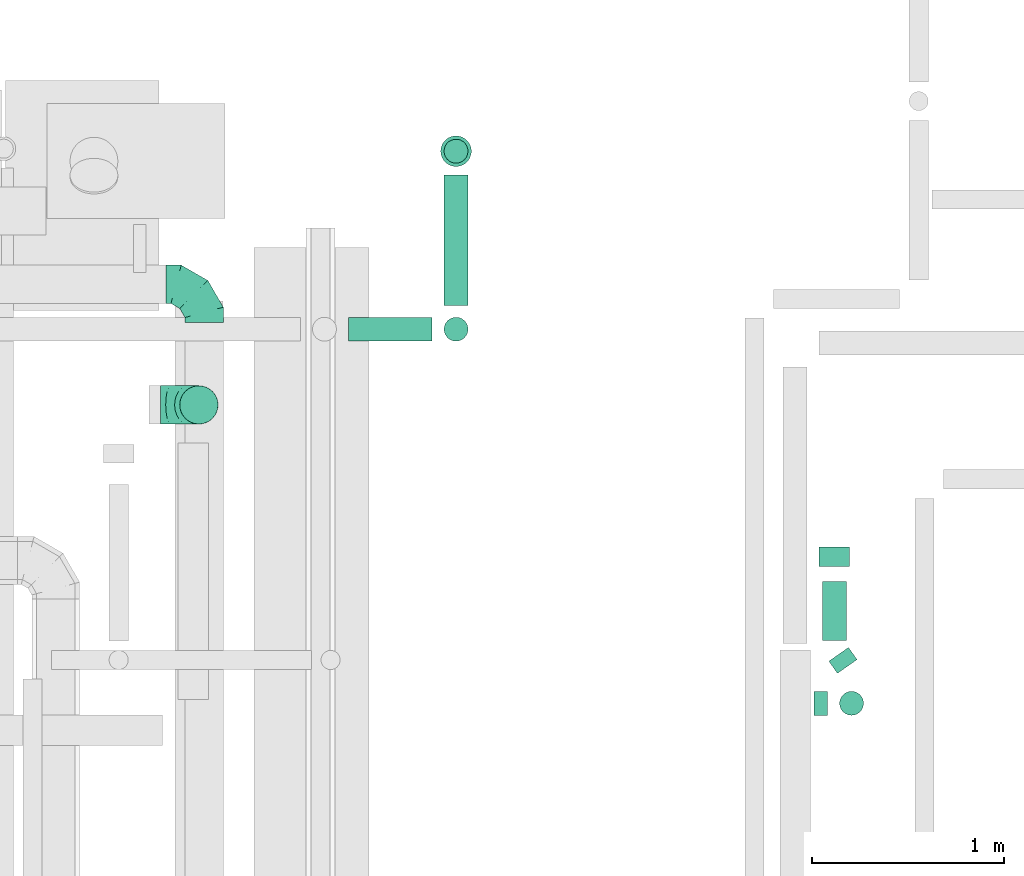
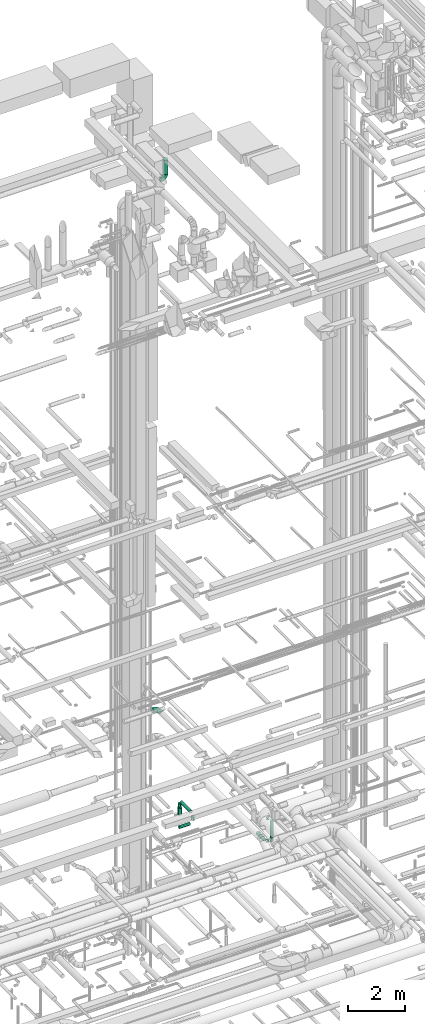
# One storey, part 294 of 337: 11 flow segments, 3 flow fittings.
"""IFC2X3 building model written with IfcOpenShell, lengths in millimetres."""

import ifcopenshell
import ifcopenshell.guid

model = None  # the IFC model being written
_history = None  # IfcOwnerHistory: only IFC2X3 demands one
_inside = {}  # id of a spatial element -> (the spatial element, [elements in it])
_under = {}  # id of a project, library or spatial element -> (it, [spatial elements below it])
_declared = {}  # id of a project -> (the project, [libraries it declares])
_typed = {}  # id of a type object -> (the type object, [elements of that type])
_made_of = {}  # id of a material, layer set ... -> (it, [elements and type objects made of it])


def new_model(schema):
    """Start an empty IFC model of exactly this schema.

    Asked for "IFC4X3", IfcOpenShell would pick the latest addendum, in which some entities
    have other attributes; the version numbers below select the first issue.
    IFC2X3 requires an IfcOwnerHistory on every rooted entity: one is made here for all.
    """
    global model, _history
    if schema == "IFC4X3":
        model = ifcopenshell.file(schema_version=(4, 3, 0, 0))
    else:
        model = ifcopenshell.file(schema=schema)
    _inside.clear()
    _under.clear()
    _declared.clear()
    _typed.clear()
    _made_of.clear()
    _history = None
    if model.schema == "IFC2X3":
        org = make("IfcOrganization", Name="unknown")
        user = make(
            "IfcPersonAndOrganization",
            ThePerson=make("IfcPerson", FamilyName="unknown"),
            TheOrganization=org,
        )
        app = make(
            "IfcApplication",
            ApplicationDeveloper=org,
            Version="unknown",
            ApplicationFullName="unknown",
            ApplicationIdentifier="unknown",
        )
        _history = make(
            "IfcOwnerHistory",
            OwningUser=user,
            OwningApplication=app,
            ChangeAction="ADDED",
            CreationDate=0,
        )
    return model


def make(cls, **values):
    """One entity of the class cls with the attributes given. An attribute that is None is left unset."""
    return model.create_entity(
        cls, **{name: value for name, value in values.items() if value is not None}
    )


def entity(cls, *values):
    """Any entity or typed value of the class cls, its attributes in the order of the schema. None: left unset."""
    e = model.create_entity(cls)
    for i, value in enumerate(values):
        if value is not None:
            e[i] = value
    return e


def rooted(cls, **values):
    """An entity with a GlobalId (a new one), such as an element, a storey or a relation."""
    return make(cls, GlobalId=ifcopenshell.guid.new(), OwnerHistory=_history, **values)


def si_unit(unit_type, name, prefix=None):
    """IfcSIUnit, for example si_unit("LENGTHUNIT", "METRE", prefix="MILLI")."""
    return make("IfcSIUnit", UnitType=unit_type, Prefix=prefix, Name=name)


def converted_unit(unit_type, name, factor, base, dimensions=None, offset=None):
    """IfcConversionBasedUnit, such as the inch: factor (a typed value) times the base unit."""
    return make(
        "IfcConversionBasedUnit"
        if offset is None
        else "IfcConversionBasedUnitWithOffset",
        ConversionOffset=offset,
        Dimensions=None
        if dimensions is None
        else entity("IfcDimensionalExponents", *dimensions),
        UnitType=unit_type,
        Name=name,
        ConversionFactor=make(
            "IfcMeasureWithUnit", ValueComponent=factor, UnitComponent=base
        ),
    )


def derived_unit(unit_type, elements):
    """IfcDerivedUnit: a product of units, each with its exponent."""
    return make(
        "IfcDerivedUnit",
        Elements=[
            make("IfcDerivedUnitElement", Unit=unit, Exponent=power)
            for unit, power in elements
        ],
        UnitType=unit_type,
    )


def assignment(units):
    """IfcUnitAssignment: the units of a project."""
    return None if units is None else make("IfcUnitAssignment", Units=units)


def point(xyz):
    """IfcCartesianPoint."""
    return None if xyz is None else make("IfcCartesianPoint", Coordinates=xyz)


def direction(xyz):
    """IfcDirection."""
    return None if xyz is None else make("IfcDirection", DirectionRatios=xyz)


def frame(location, z_axis=None, x_axis=None):
    """IfcAxis2Placement3D, a coordinate frame: its origin and axes. An axis left out is left unset."""
    return make(
        "IfcAxis2Placement3D",
        Location=point(location),
        Axis=direction(z_axis),
        RefDirection=direction(x_axis),
    )


def frame_2d(location, x_axis=None):
    """IfcAxis2Placement2D, a coordinate frame in the plane: its origin and x axis."""
    return make(
        "IfcAxis2Placement2D", Location=point(location), RefDirection=direction(x_axis)
    )


def origin():
    """The frame at (0, 0, 0) with its axes left unset."""
    return frame((0.0, 0.0, 0.0))


def origin_2d_with_axis():
    """The frame at (0, 0) in the plane with the x axis (1, 0) written out."""
    return frame_2d((0.0, 0.0), x_axis=(1.0, 0.0))


def place(relative_to, where):
    """IfcLocalPlacement: puts the frame where relative to a parent placement (None: the world)."""
    return make(
        "IfcLocalPlacement", PlacementRelTo=relative_to, RelativePlacement=where
    )


def context(
    kind, dimensions, precision=None, world=None, true_north=None, identifier=None
):
    """IfcGeometricRepresentationContext, for example the 3D "Model" context."""
    return make(
        "IfcGeometricRepresentationContext",
        ContextIdentifier=identifier,
        ContextType=kind,
        CoordinateSpaceDimension=dimensions,
        Precision=precision,
        WorldCoordinateSystem=world,
        TrueNorth=true_north,
    )


def subcontext(parent, identifier, kind, view, scale=None):
    """IfcGeometricRepresentationSubContext, for example "Body" below "Model"."""
    return make(
        "IfcGeometricRepresentationSubContext",
        ContextIdentifier=identifier,
        ContextType=kind,
        ParentContext=parent,
        TargetScale=scale,
        TargetView=view,
    )


def project(units=None, contexts=None):
    """IfcProject with its units and contexts."""
    return rooted(
        "IfcProject",
        Name="project",
        RepresentationContexts=contexts,
        UnitsInContext=assignment(units),
    )


def spatial(cls, under=None, at=None, **own):
    """A site, building, storey or space (cls), placed at a placement, below another one or the project."""
    s = rooted(cls, ObjectPlacement=at, **own)
    if under is not None:
        _under.setdefault(under.id(), (under, []))[1].append(s)
    return s


def profile(cls, at=None, kind="AREA", **sizes):
    """A parametric profile (cls). Its sizes go by their IFC names, for example OverallWidth=200.0."""
    return make(cls, ProfileType=kind, Position=at, **sizes)


def circle(**sizes):
    """IfcCircleProfileDef."""
    return profile("IfcCircleProfileDef", **sizes)


def extrude(swept, where, along, depth):
    """IfcExtrudedAreaSolid: the profile swept, set in the frame where, extruded along a direction by depth."""
    return make(
        "IfcExtrudedAreaSolid",
        SweptArea=swept,
        Position=where,
        ExtrudedDirection=direction(along),
        Depth=depth,
    )


def faces_of(points, faces, orient=None, outer=None):
    """IfcFace entities. A face is a list of loops; a loop is a list of indices into points, from 0.

    orient and outer hold one flag for each loop. By default every Orientation is true, the
    first loop of a face is its IfcFaceOuterBound and the others are IfcFaceBound.
    """
    made = []
    for i, loops in enumerate(faces):
        bounds = []
        for j, loop in enumerate(loops):
            is_outer = j == 0 if outer is None else outer[i][j]
            bounds.append(
                make(
                    "IfcFaceOuterBound" if is_outer else "IfcFaceBound",
                    Bound=make("IfcPolyLoop", Polygon=[points[k] for k in loop]),
                    Orientation=True if orient is None else orient[i][j],
                )
            )
        made.append(make("IfcFace", Bounds=bounds))
    return made


def faceted_brep(points, faces, orient=None, outer=None, voids=None):
    """IfcFacetedBrep: a solid bounded by flat faces; with voids (closed shells), ...WithVoids."""
    shared = [point(p) for p in points]
    hull = make("IfcClosedShell", CfsFaces=faces_of(shared, faces, orient, outer))
    if voids is None:
        return make("IfcFacetedBrep", Outer=hull)
    return make(
        "IfcFacetedBrepWithVoids",
        Outer=hull,
        Voids=[
            make(cls, CfsFaces=faces_of(shared, fs, o, b)) for cls, fs, o, b in voids
        ],
    )


def shape(context_of_items, identifier, shape_type, items):
    """IfcShapeRepresentation: the items that make up one representation, for example the "Body"."""
    return make(
        "IfcShapeRepresentation",
        ContextOfItems=context_of_items,
        RepresentationIdentifier=identifier,
        RepresentationType=shape_type,
        Items=items,
    )


def source(mapping_origin, context_of_items, identifier, shape_type, items):
    """IfcRepresentationMap: a shape defined once, which mapped items show again and again."""
    return make(
        "IfcRepresentationMap",
        MappingOrigin=mapping_origin,
        MappedRepresentation=shape(context_of_items, identifier, shape_type, items),
    )


def transform(
    local_origin,
    x_axis=None,
    y_axis=None,
    z_axis=None,
    scale=None,
    scale2=None,
    scale3=None,
    uniform=True,
):
    """IfcCartesianTransformationOperator3D, or its non-uniform kind. x_axis, y_axis, z_axis: its Axis1, 2, 3."""
    if uniform:
        return make(
            "IfcCartesianTransformationOperator3D",
            Axis1=direction(x_axis),
            Axis2=direction(y_axis),
            LocalOrigin=point(local_origin),
            Scale=scale,
            Axis3=direction(z_axis),
        )
    return make(
        "IfcCartesianTransformationOperator3DnonUniform",
        Axis1=direction(x_axis),
        Axis2=direction(y_axis),
        LocalOrigin=point(local_origin),
        Scale=scale,
        Axis3=direction(z_axis),
        Scale2=scale2,
        Scale3=scale3,
    )


def mapped(mapping_source, mapping_target):
    """IfcMappedItem: shows the shape of a source again, moved by a transform."""
    return make(
        "IfcMappedItem", MappingSource=mapping_source, MappingTarget=mapping_target
    )


def material(Name=None, Category=None):
    """IfcMaterial."""
    return make("IfcMaterial", Name=Name, Category=Category)


def made_of(thing, what):
    """Note that an element or type object is made of a material, layer set ...; save() writes the relation."""
    if what is not None:
        _made_of.setdefault(what.id(), (what, []))[1].append(thing)
    return thing


def type_object(cls, material=None, **own):
    """A type object (cls), such as IfcWallType, which elements share."""
    return made_of(rooted(cls, **own), material)


def type_shapes(of_type, sources):
    """Give a type object the sources (RepresentationMaps) that its elements show as mapped items."""
    of_type.RepresentationMaps = sources


def element(
    cls,
    number,
    at=None,
    inside=None,
    cuts=None,
    type_object=None,
    material=None,
    context=None,
    identifier="Body",
    shape_type=None,
    held_by="IfcProductDefinitionShape",
    body=None,
    shapes=None,
    **own,
):
    """One element of the class cls, such as IfcWall. Its Tag is "e" and its number.

    at: its placement. inside: the storey or other place that contains it. cuts: it is an
    opening in that element (IfcRelVoidsElement). A single representation is given by context,
    identifier, shape_type and body (its items); several are given by shapes. held_by: the class
    of the entity that holds the representations. save() writes the other relations.
    """
    e = rooted(cls, Tag="e%d" % number, ObjectPlacement=at, **own)
    if body is not None:
        shapes = [shape(context, identifier, shape_type, body)]
    if shapes is not None:
        e.Representation = make(held_by, Representations=shapes)
    if inside is not None:
        _inside.setdefault(inside.id(), (inside, []))[1].append(e)
    if cuts is not None:
        rooted(
            "IfcRelVoidsElement", RelatingBuildingElement=cuts, RelatedOpeningElement=e
        )
    if type_object is not None:
        _typed.setdefault(type_object.id(), (type_object, []))[1].append(e)
    return made_of(e, material)


def aggregate(whole, parts):
    """IfcRelAggregates: a whole, such as a stair, and the parts it consists of."""
    return rooted("IfcRelAggregates", RelatingObject=whole, RelatedObjects=parts)


def save(model, path):
    """Write the relations noted so far, then the file.

    IfcRelAggregates (storeys below a building ...), IfcRelContainedInSpatialStructure (elements
    in a storey), IfcRelDefinesByType, IfcRelAssociatesMaterial and IfcRelDeclares: one each for
    every whole, place, type object, material and project.
    """
    for whole, parts in _under.values():
        aggregate(whole, parts)
    for where, things in _inside.values():
        rooted(
            "IfcRelContainedInSpatialStructure",
            RelatedElements=things,
            RelatingStructure=where,
        )
    for kind, things in _typed.values():
        rooted("IfcRelDefinesByType", RelatedObjects=things, RelatingType=kind)
    for what, things in _made_of.values():
        rooted("IfcRelAssociatesMaterial", RelatedObjects=things, RelatingMaterial=what)
    for by, libraries in _declared.values():
        rooted("IfcRelDeclares", RelatingContext=by, RelatedDefinitions=libraries)
    model.write(path)


model = new_model("IFC2X3")

# Units and contexts
model_context = context("Model", 3, precision=0.01, world=origin(), true_north=direction((6.12303176911189e-17, 1.0)))
body_context = subcontext(model_context, "Body", "Model", "MODEL_VIEW")
ifc_project = project(units=[si_unit("LENGTHUNIT", "METRE", prefix="MILLI"), si_unit("AREAUNIT", "SQUARE_METRE"), si_unit("VOLUMEUNIT", "CUBIC_METRE"), converted_unit("PLANEANGLEUNIT", "DEGREE", entity("IfcRatioMeasure", 0.0174532925199433), si_unit("PLANEANGLEUNIT", "RADIAN"), dimensions=[0, 0, 0, 0, 0, 0, 0]), si_unit("MASSUNIT", "GRAM", prefix="KILO"), derived_unit("MASSDENSITYUNIT", [(si_unit("MASSUNIT", "GRAM", prefix="KILO"), 1), (si_unit("LENGTHUNIT", "METRE"), -3)]), derived_unit("MOMENTOFINERTIAUNIT", [(si_unit("LENGTHUNIT", "METRE"), 4)]), si_unit("TIMEUNIT", "SECOND"), si_unit("FREQUENCYUNIT", "HERTZ"), si_unit("THERMODYNAMICTEMPERATUREUNIT", "DEGREE_CELSIUS"), derived_unit("THERMALTRANSMITTANCEUNIT", [(si_unit("MASSUNIT", "GRAM", prefix="KILO"), 1), (si_unit("THERMODYNAMICTEMPERATUREUNIT", "KELVIN"), -1), (si_unit("TIMEUNIT", "SECOND"), -3)]), derived_unit("VOLUMETRICFLOWRATEUNIT", [(si_unit("LENGTHUNIT", "METRE"), 3), (si_unit("TIMEUNIT", "SECOND"), -1)]), derived_unit("MASSFLOWRATEUNIT", [(si_unit("MASSUNIT", "GRAM", prefix="KILO"), 1), (si_unit("TIMEUNIT", "SECOND"), -1)]), derived_unit("ROTATIONALFREQUENCYUNIT", [(si_unit("TIMEUNIT", "SECOND"), -1)]), si_unit("ELECTRICCURRENTUNIT", "AMPERE"), si_unit("ELECTRICVOLTAGEUNIT", "VOLT"), si_unit("POWERUNIT", "WATT"), si_unit("FORCEUNIT", "NEWTON", prefix="KILO"), si_unit("ILLUMINANCEUNIT", "LUX"), si_unit("LUMINOUSFLUXUNIT", "LUMEN"), si_unit("LUMINOUSINTENSITYUNIT", "CANDELA"), derived_unit("USERDEFINED", [(si_unit("MASSUNIT", "GRAM", prefix="KILO"), -1), (si_unit("LENGTHUNIT", "METRE"), -2), (si_unit("TIMEUNIT", "SECOND"), 3), (si_unit("LUMINOUSFLUXUNIT", "LUMEN"), 1)]), derived_unit("LINEARVELOCITYUNIT", [(si_unit("LENGTHUNIT", "METRE"), 1), (si_unit("TIMEUNIT", "SECOND"), -1)]), si_unit("PRESSUREUNIT", "PASCAL"), derived_unit("USERDEFINED", [(si_unit("LENGTHUNIT", "METRE"), -2), (si_unit("MASSUNIT", "GRAM", prefix="KILO"), 1), (si_unit("TIMEUNIT", "SECOND"), -2)]), derived_unit("LINEARFORCEUNIT", [(si_unit("MASSUNIT", "GRAM", prefix="KILO"), 1), (si_unit("LENGTHUNIT", "METRE"), 1), (si_unit("TIMEUNIT", "SECOND"), -2), (si_unit("LENGTHUNIT", "METRE"), -1)]), derived_unit("PLANARFORCEUNIT", [(si_unit("MASSUNIT", "GRAM", prefix="KILO"), 1), (si_unit("LENGTHUNIT", "METRE"), 1), (si_unit("TIMEUNIT", "SECOND"), -2), (si_unit("LENGTHUNIT", "METRE"), -2)])], contexts=[model_context])

# Site, building, storey
site_placement = place(None, origin())
site = spatial("IfcSite", under=ifc_project, at=site_placement, CompositionType="ELEMENT")
building_placement = place(site_placement, origin())
building = spatial("IfcBuilding", under=site, at=building_placement, CompositionType="ELEMENT")
storey_placement = place(building_placement, origin())
storey = spatial("IfcBuildingStorey", under=building, at=storey_placement, CompositionType="ELEMENT", Elevation=0.0)

# Flow segments
duct_segment_type = type_object("IfcDuctSegmentType", PredefinedType="NOTDEFINED")
flow_segment_1_placement = place(storey_placement, frame((65163.17, 18742.36, -1664.1)))
element("IfcFlowSegment", 1, at=flow_segment_1_placement, inside=storey, type_object=duct_segment_type, context=body_context, shape_type="SweptSolid", body=[
    extrude(circle(Radius=62.5, at=origin_2d_with_axis()), frame((0.0, 64.1, 64.1), z_axis=(1.0, 0.0, 0.0), x_axis=(0.0, -1.0, 0.0)), (0.0, 0.0, 1.0), 436.478230000029),
])
flow_segment_2_placement = place(storey_placement, frame((65660.55, 18742.36, -1475.0)))
element("IfcFlowSegment", 2, at=flow_segment_2_placement, inside=storey, type_object=duct_segment_type, context=body_context, shape_type="SweptSolid", body=[
    extrude(circle(Radius=62.5, at=origin_2d_with_axis()), frame((64.1, 64.1, 0.0), z_axis=(0.0, 0.0, 1.0), x_axis=(0.0, -1.0, 0.0)), (0.0, 0.0, 1.0), 150.000000000006),
])
flow_segment_3_placement = place(storey_placement, frame((65660.55, 18931.46, -1264.1)))
element("IfcFlowSegment", 3, at=flow_segment_3_placement, inside=storey, type_object=duct_segment_type, context=body_context, shape_type="SweptSolid", body=[
    extrude(circle(Radius=62.5, at=origin_2d_with_axis()), frame((64.1, 0.0, 64.1), z_axis=(0.0, 1.0, 0.0), x_axis=(1.0, 0.0, 0.0)), (0.0, 0.0, 1.0), 679.225240000004),
])
flow_segment_4_placement = place(storey_placement, frame((65643.05, 19654.09, -1800.0)))
element("IfcFlowSegment", 4, at=flow_segment_4_placement, inside=storey, type_object=duct_segment_type, context=body_context, shape_type="SweptSolid", body=[
    extrude(circle(Radius=80.0, at=origin_2d_with_axis()), frame((81.6, 81.6, 0.0), z_axis=(0.0, 0.0, 1.0), x_axis=(-1.0, 0.0, 0.0)), (0.0, 0.0, 1.0), 299.0),
])
flow_segment_5_placement = place(storey_placement, frame((65660.55, 19671.59, -1466.0)))
element("IfcFlowSegment", 5, at=flow_segment_5_placement, inside=storey, type_object=duct_segment_type, context=body_context, shape_type="SweptSolid", body=[
    extrude(circle(Radius=62.5, at=origin_2d_with_axis()), frame((64.1, 64.1, 0.0)), (0.0, 0.0, 1.0), 140.999999999994),
])
flow_segment_6_placement = place(storey_placement, frame((67594.2, 16789.8, -964.1)))
element("IfcFlowSegment", 6, at=flow_segment_6_placement, inside=storey, type_object=duct_segment_type, context=body_context, shape_type="SweptSolid", body=[
    extrude(circle(Radius=62.5, at=origin_2d_with_axis()), frame((0.0, 64.1, 64.1), z_axis=(1.0, 0.0, 0.0), x_axis=(0.0, 1.0, 0.0)), (0.0, 0.0, 1.0), 69.7791300000129),
])
flow_segment_7_placement = place(storey_placement, frame((67724.89, 16789.8, -1915.0)))
element("IfcFlowSegment", 7, at=flow_segment_7_placement, inside=storey, type_object=duct_segment_type, context=body_context, shape_type="SweptSolid", body=[
    extrude(circle(Radius=62.5, at=origin_2d_with_axis()), frame((64.1, 64.1, 0.0), z_axis=(0.0, 0.0, 1.0), x_axis=(0.0, -1.0, 0.0)), (0.0, 0.0, 1.0), 890.000000000015),
])
flow_segment_8_placement = place(storey_placement, frame((67669.13, 17008.73, -2104.1)))
element("IfcFlowSegment", 8, at=flow_segment_8_placement, inside=storey, type_object=duct_segment_type, context=body_context, shape_type="SweptSolid", body=[
    extrude(circle(Radius=62.5, at=origin_2d_with_axis()), frame((52.79, 100.93, 64.1), z_axis=(0.573576436351316, -0.819152044288803, 0.0), x_axis=(0.819152044288803, 0.573576436351316, 0.0)), (0.0, 0.0, 1.0), 77.4998034351492),
])
flow_segment_9_placement = place(storey_placement, frame((67617.72, 17568.91, -2121.6)))
element("IfcFlowSegment", 9, at=flow_segment_9_placement, inside=storey, type_object=duct_segment_type, context=body_context, shape_type="SweptSolid", body=[
    extrude(circle(Radius=80.0, at=origin_2d_with_axis()), frame((81.6, 0.0, 81.6), z_axis=(0.0, 1.0, 0.0), x_axis=(1.0, 0.0, 0.0)), (0.0, 0.0, 1.0), 99.9999999999989),
])
flow_segment_10_placement = place(storey_placement, frame((67635.22, 17181.36, -2104.1)))
element("IfcFlowSegment", 10, at=flow_segment_10_placement, inside=storey, type_object=duct_segment_type, context=body_context, shape_type="SweptSolid", body=[
    extrude(circle(Radius=62.5, at=origin_2d_with_axis()), frame((64.1, 0.0, 64.1), z_axis=(0.0, 1.0, 0.0), x_axis=(1.0, 0.0, 0.0)), (0.0, 0.0, 1.0), 309.555798214336),
])
flow_segment_11_placement = place(storey_placement, frame((64281.05, 18309.88, 26950.0)))
element("IfcFlowSegment", 11, at=flow_segment_11_placement, inside=storey, type_object=duct_segment_type, context=body_context, shape_type="SweptSolid", body=[
    extrude(circle(Radius=100.0, at=origin_2d_with_axis()), frame((101.6, 101.6, 0.0), z_axis=(0.0, 0.0, 1.0), x_axis=(0.0, -1.0, 0.0)), (0.0, 0.0, 1.0), 580.000000000007),
])

# Flow fittings
ifc_material = material()
duct_fitting_type_1 = type_object("IfcDuctFittingType", PredefinedType="NOTDEFINED", material=ifc_material)
shared_shape_1 = source(origin(), body_context, "Body", "Brep", [
    faceted_brep([(-200.0, 0.0, -100.0), (-200.0, -25.88, -96.59), (-200.0, -50.0, -86.6), (-200.0, -70.71, -70.71), (-200.0, -86.6, -50.0), (-200.0, -96.59, -25.88), (-200.0, -100.0, 0.0), (-200.0, -96.59, 25.88), (-200.0, -86.6, 50.0), (-200.0, -70.71, 70.71), (-200.0, -50.0, 86.6), (-200.0, -25.88, 96.59), (-200.0, 0.0, 100.0), (-200.0, 25.88, 96.59), (-200.0, 50.0, 86.6), (-200.0, 70.71, 70.71), (-200.0, 86.6, 50.0), (-200.0, 96.59, 25.88), (-200.0, 100.0, 0.0), (-200.0, 96.59, -25.88), (-200.0, 86.6, -50.0), (-200.0, 70.71, -70.71), (-200.0, 50.0, -86.6), (-200.0, 25.88, -96.59), (-153.35, 25.88, 96.59), (-159.81, 50.0, 86.6), (-146.41, 0.0, 100.0), (-165.36, 70.71, 70.71), (-172.29, 96.59, 25.88), (-173.21, 100.0, 0.0), (-169.62, 86.6, 50.0), (-169.62, 86.6, -50.0), (-165.36, 70.71, -70.71), (-172.29, 96.59, -25.88), (-153.35, 25.88, -96.59), (-146.41, 0.0, -100.0), (-159.81, 50.0, -86.6), (-139.48, -25.88, -96.59), (-133.01, -50.0, -86.6), (-127.46, -70.71, -70.71), (-123.21, -86.6, -50.0), (-120.53, -96.59, -25.88), (-119.62, -100.0, 0.0), (-120.53, -96.59, 25.88), (-123.21, -86.6, 50.0), (-127.46, -70.71, 70.71), (-133.01, -50.0, 86.6), (-139.48, -25.88, 96.59), (-72.54, 72.54, 96.59), (-90.19, 90.19, 86.6), (-53.59, 53.59, 100.0), (-105.35, 105.35, 70.71), (-116.99, 116.99, 50.0), (-124.3, 124.3, 25.88), (-126.79, 126.79, 0.0), (-124.3, 124.3, -25.88), (-116.99, 116.99, -50.0), (-105.35, 105.35, -70.71), (-72.54, 72.54, -96.59), (-53.59, 53.59, -100.0), (-90.19, 90.19, -86.6), (-34.64, 34.64, -96.59), (-16.99, 16.99, -86.6), (-1.83, 1.83, -70.71), (9.81, -9.81, -50.0), (17.12, -17.12, -25.88), (19.62, -19.62, 0.0), (17.12, -17.12, 25.88), (9.81, -9.81, 50.0), (-1.83, 1.83, 70.71), (-16.99, 16.99, 86.6), (-34.64, 34.64, 96.59), (-25.88, 153.35, 96.59), (-50.0, 159.81, 86.6), (0.0, 146.41, 100.0), (-70.71, 165.36, 70.71), (-86.6, 169.62, 50.0), (-96.59, 172.29, 25.88), (-100.0, 173.21, 0.0), (-96.59, 172.29, -25.88), (-86.6, 169.62, -50.0), (-70.71, 165.36, -70.71), (-25.88, 153.35, -96.59), (0.0, 146.41, -100.0), (-50.0, 159.81, -86.6), (25.88, 139.48, -96.59), (50.0, 133.01, -86.6), (70.71, 127.46, -70.71), (86.6, 123.21, -50.0), (96.59, 120.53, -25.88), (100.0, 119.62, 0.0), (96.59, 120.53, 25.88), (86.6, 123.21, 50.0), (70.71, 127.46, 70.71), (50.0, 133.01, 86.6), (25.88, 139.48, 96.59), (-25.88, 200.0, -96.59), (-50.0, 200.0, -86.6), (-70.71, 200.0, -70.71), (-86.6, 200.0, -50.0), (-96.59, 200.0, -25.88), (-100.0, 200.0, 0.0), (-96.59, 200.0, 25.88), (-86.6, 200.0, 50.0), (-70.71, 200.0, 70.71), (-50.0, 200.0, 86.6), (-25.88, 200.0, 96.59), (0.0, 200.0, 100.0), (25.88, 200.0, 96.59), (50.0, 200.0, 86.6), (70.71, 200.0, 70.71), (86.6, 200.0, 50.0), (96.59, 200.0, 25.88), (100.0, 200.0, 0.0), (96.59, 200.0, -25.88), (86.6, 200.0, -50.0), (70.71, 200.0, -70.71), (50.0, 200.0, -86.6), (25.88, 200.0, -96.59), (0.0, 200.0, -100.0)], [[[0, 1, 2, 3, 4, 5, 6, 7, 8, 9, 10, 11, 12, 13, 14, 15, 16, 17, 18, 19, 20, 21, 22, 23]], [[24, 25, 14, 13]], [[26, 24, 13, 12]], [[14, 25, 27, 15]], [[28, 29, 18, 17]], [[30, 28, 17, 16]], [[15, 27, 30, 16]], [[20, 31, 32, 21]], [[33, 31, 20, 19]], [[18, 29, 33, 19]], [[34, 35, 0, 23]], [[36, 34, 23, 22]], [[32, 36, 22, 21]], [[1, 0, 35, 37]], [[2, 1, 37, 38]], [[38, 39, 3, 2]], [[5, 4, 40, 41]], [[6, 5, 41, 42]], [[39, 40, 4, 3]], [[6, 42, 43, 7]], [[7, 43, 44, 8]], [[8, 44, 45, 9]], [[9, 45, 46, 10]], [[10, 46, 47, 11]], [[26, 12, 11, 47]], [[48, 49, 25, 24]], [[50, 48, 24, 26]], [[27, 25, 49, 51]], [[52, 53, 28, 30]], [[51, 52, 30, 27]], [[29, 28, 53, 54]], [[55, 56, 31, 33]], [[54, 55, 33, 29]], [[32, 31, 56, 57]], [[58, 59, 35, 34]], [[60, 58, 34, 36]], [[57, 60, 36, 32]], [[37, 35, 59, 61]], [[38, 37, 61, 62]], [[39, 38, 62, 63]], [[41, 40, 64, 65]], [[42, 41, 65, 66]], [[63, 64, 40, 39]], [[43, 42, 66, 67]], [[44, 43, 67, 68]], [[68, 69, 45, 44]], [[46, 45, 69, 70]], [[47, 46, 70, 71]], [[26, 47, 71, 50]], [[72, 73, 49, 48]], [[74, 72, 48, 50]], [[51, 49, 73, 75]], [[76, 77, 53, 52]], [[75, 76, 52, 51]], [[54, 53, 77, 78]], [[79, 80, 56, 55]], [[78, 79, 55, 54]], [[57, 56, 80, 81]], [[82, 83, 59, 58]], [[84, 82, 58, 60]], [[81, 84, 60, 57]], [[61, 59, 83, 85]], [[62, 61, 85, 86]], [[63, 62, 86, 87]], [[65, 64, 88, 89]], [[66, 65, 89, 90]], [[87, 88, 64, 63]], [[67, 66, 90, 91]], [[68, 67, 91, 92]], [[92, 93, 69, 68]], [[70, 69, 93, 94]], [[71, 70, 94, 95]], [[50, 71, 95, 74]], [[96, 97, 98, 99, 100, 101, 102, 103, 104, 105, 106, 107, 108, 109, 110, 111, 112, 113, 114, 115, 116, 117, 118, 119]], [[72, 74, 107, 106]], [[73, 72, 106, 105]], [[75, 73, 105, 104]], [[102, 101, 78, 77]], [[103, 102, 77, 76]], [[75, 104, 103, 76]], [[78, 101, 100, 79]], [[79, 100, 99, 80]], [[80, 99, 98, 81]], [[84, 97, 96, 82]], [[82, 96, 119, 83]], [[84, 81, 98, 97]], [[118, 117, 86, 85]], [[119, 118, 85, 83]], [[116, 87, 86, 117]], [[88, 115, 114, 89]], [[89, 114, 113, 90]], [[115, 88, 87, 116]], [[91, 90, 113, 112]], [[92, 91, 112, 111]], [[111, 110, 93, 92]], [[95, 94, 109, 108]], [[74, 95, 108, 107]], [[110, 109, 94, 93]]]),
])
type_shapes(duct_fitting_type_1, [shared_shape_1])
for number, where, z_axis, x_axis in (
    (12, (64410.14, 19040.8, 3600.0), (0.0, 0.0, 1.0), (0.0, 1.0, 0.0)),
    (13, (64382.65, 18411.48, 26750.0), (0.0, -1.0, 0.0), (1.0, 0.0, 0.0)),
):
    element("IfcFlowFitting", number, at=place(storey_placement, frame(where, z_axis=z_axis, x_axis=x_axis)), inside=storey, type_object=duct_fitting_type_1, material=ifc_material, context=body_context, shape_type="MappedRepresentation", body=[
        mapped(shared_shape_1, transform((0.0, 0.0, 0.0), scale=1.0)),
    ])
duct_fitting_type_2 = type_object("IfcDuctFittingType", PredefinedType="NOTDEFINED", material=ifc_material)
shared_shape_2 = source(origin(), body_context, "Body", "Brep", [
    faceted_brep([(20.0, 25.88, -96.59), (20.0, 50.0, -86.6), (20.0, 70.71, -70.71), (20.0, 86.6, -50.0), (20.0, 96.59, -25.88), (20.0, 100.0, 0.0), (20.0, 96.59, 25.88), (20.0, 86.6, 50.0), (20.0, 70.71, 70.71), (20.0, 50.0, 86.6), (20.0, 25.88, 96.59), (20.0, 0.0, 100.0), (20.0, -25.88, 96.59), (20.0, -50.0, 86.6), (20.0, -70.71, 70.71), (20.0, -86.6, 50.0), (20.0, -96.59, 25.88), (20.0, -100.0, 0.0), (20.0, -96.59, -25.88), (20.0, -86.6, -50.0), (20.0, -70.71, -70.71), (20.0, -50.0, -86.6), (20.0, -25.88, -96.59), (20.0, 0.0, -100.0), (0.0, 0.0, 100.0), (0.0, 25.88, 96.59), (-6.1, 25.88, 96.59), (-6.1, 0.0, 100.0), (0.0, 50.0, 86.6), (-6.1, 50.0, 86.6), (0.0, 70.71, 70.71), (-6.1, 70.71, 70.71), (0.0, 86.6, 50.0), (0.0, 96.59, 25.88), (-6.1, 96.59, 25.88), (-6.1, 86.6, 50.0), (0.0, 100.0, 0.0), (-6.1, 100.0, 0.0), (0.0, 96.59, -25.88), (-6.1, 96.59, -25.88), (0.0, 86.6, -50.0), (-6.1, 86.6, -50.0), (0.0, 70.71, -70.71), (-6.1, 70.71, -70.71), (0.0, 50.0, -86.6), (0.0, 25.88, -96.59), (-6.1, 25.88, -96.59), (-6.1, 50.0, -86.6), (0.0, 0.0, -100.0), (-6.1, 0.0, -100.0), (0.0, -25.88, -96.59), (-6.1, -25.88, -96.59), (0.0, -50.0, -86.6), (-6.1, -50.0, -86.6), (0.0, -70.71, -70.71), (-6.1, -70.71, -70.71), (0.0, -86.6, -50.0), (0.0, -96.59, -25.88), (-6.1, -96.59, -25.88), (-6.1, -86.6, -50.0), (0.0, -100.0, 0.0), (-6.1, -100.0, 0.0), (0.0, -96.59, 25.88), (-6.1, -96.59, 25.88), (0.0, -86.6, 50.0), (-6.1, -86.6, 50.0), (0.0, -70.71, 70.71), (-6.1, -70.71, 70.71), (0.0, -50.0, 86.6), (0.0, -25.88, 96.59), (-6.1, -25.88, 96.59), (-6.1, -50.0, 86.6)], [[[0, 1, 2, 3, 4, 5, 6, 7, 8, 9, 10, 11, 12, 13, 14, 15, 16, 17, 18, 19, 20, 21, 22, 23]], [[24, 11, 10, 25, 26, 27]], [[25, 10, 9, 28, 29, 26]], [[28, 9, 8, 30, 31, 29]], [[32, 7, 6, 33, 34, 35]], [[33, 6, 5, 36, 37, 34]], [[30, 8, 7, 32, 35, 31]], [[36, 5, 4, 38, 39, 37]], [[38, 4, 3, 40, 41, 39]], [[40, 3, 2, 42, 43, 41]], [[44, 1, 0, 45, 46, 47]], [[45, 0, 23, 48, 49, 46]], [[42, 2, 1, 44, 47, 43]], [[48, 23, 22, 50, 51, 49]], [[50, 22, 21, 52, 53, 51]], [[52, 21, 20, 54, 55, 53]], [[56, 19, 18, 57, 58, 59]], [[57, 18, 17, 60, 61, 58]], [[54, 20, 19, 56, 59, 55]], [[60, 17, 16, 62, 63, 61]], [[62, 16, 15, 64, 65, 63]], [[64, 15, 14, 66, 67, 65]], [[68, 13, 12, 69, 70, 71]], [[69, 12, 11, 24, 27, 70]], [[66, 14, 13, 68, 71, 67]], [[49, 51, 53, 55, 59, 58, 61, 63, 65, 67, 71, 70, 27, 26, 29, 31, 35, 34, 37, 39, 41, 43, 47, 46]]]),
])
type_shapes(duct_fitting_type_2, [shared_shape_2])
flow_fitting_placement = place(storey_placement, frame((64382.65, 18411.48, 27550.0), z_axis=(-1.0, 0.0, 0.0), x_axis=(0.0, 0.0, -1.0)))
element("IfcFlowFitting", 14, at=flow_fitting_placement, inside=storey, type_object=duct_fitting_type_2, material=ifc_material, context=body_context, shape_type="MappedRepresentation", body=[
    mapped(shared_shape_2, transform((0.0, 0.0, 0.0), scale=1.0)),
])

save(model, "model.ifc")
